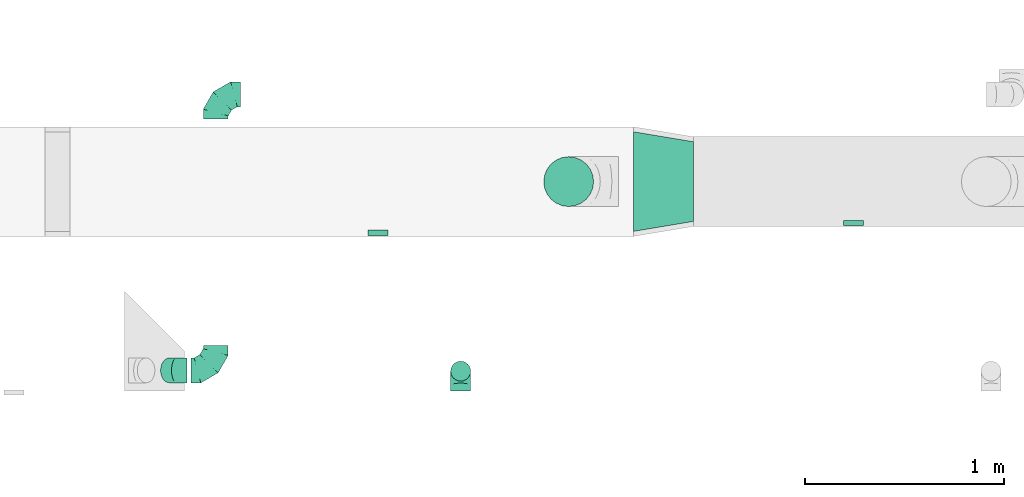
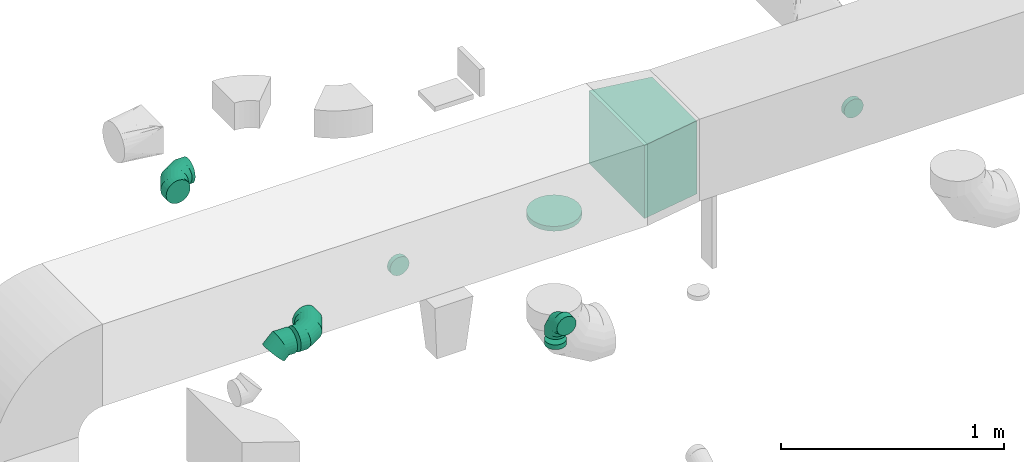
# One storey, part 61 of 97: 9 flow fittings.
"""IFC2X3 building model written with IfcOpenShell, lengths in millimetres."""

import ifcopenshell
import ifcopenshell.guid

model = None  # the IFC model being written
_history = None  # IfcOwnerHistory: only IFC2X3 demands one
_inside = {}  # id of a spatial element -> (the spatial element, [elements in it])
_under = {}  # id of a project, library or spatial element -> (it, [spatial elements below it])
_declared = {}  # id of a project -> (the project, [libraries it declares])
_typed = {}  # id of a type object -> (the type object, [elements of that type])
_made_of = {}  # id of a material, layer set ... -> (it, [elements and type objects made of it])


def new_model(schema):
    """Start an empty IFC model of exactly this schema.

    Asked for "IFC4X3", IfcOpenShell would pick the latest addendum, in which some entities
    have other attributes; the version numbers below select the first issue.
    IFC2X3 requires an IfcOwnerHistory on every rooted entity: one is made here for all.
    """
    global model, _history
    if schema == "IFC4X3":
        model = ifcopenshell.file(schema_version=(4, 3, 0, 0))
    else:
        model = ifcopenshell.file(schema=schema)
    _inside.clear()
    _under.clear()
    _declared.clear()
    _typed.clear()
    _made_of.clear()
    _history = None
    if model.schema == "IFC2X3":
        org = make("IfcOrganization", Name="unknown")
        user = make(
            "IfcPersonAndOrganization",
            ThePerson=make("IfcPerson", FamilyName="unknown"),
            TheOrganization=org,
        )
        app = make(
            "IfcApplication",
            ApplicationDeveloper=org,
            Version="unknown",
            ApplicationFullName="unknown",
            ApplicationIdentifier="unknown",
        )
        _history = make(
            "IfcOwnerHistory",
            OwningUser=user,
            OwningApplication=app,
            ChangeAction="ADDED",
            CreationDate=0,
        )
    return model


def make(cls, **values):
    """One entity of the class cls with the attributes given. An attribute that is None is left unset."""
    return model.create_entity(
        cls, **{name: value for name, value in values.items() if value is not None}
    )


def entity(cls, *values):
    """Any entity or typed value of the class cls, its attributes in the order of the schema. None: left unset."""
    e = model.create_entity(cls)
    for i, value in enumerate(values):
        if value is not None:
            e[i] = value
    return e


def rooted(cls, **values):
    """An entity with a GlobalId (a new one), such as an element, a storey or a relation."""
    return make(cls, GlobalId=ifcopenshell.guid.new(), OwnerHistory=_history, **values)


def si_unit(unit_type, name, prefix=None):
    """IfcSIUnit, for example si_unit("LENGTHUNIT", "METRE", prefix="MILLI")."""
    return make("IfcSIUnit", UnitType=unit_type, Prefix=prefix, Name=name)


def converted_unit(unit_type, name, factor, base, dimensions=None, offset=None):
    """IfcConversionBasedUnit, such as the inch: factor (a typed value) times the base unit."""
    return make(
        "IfcConversionBasedUnit"
        if offset is None
        else "IfcConversionBasedUnitWithOffset",
        ConversionOffset=offset,
        Dimensions=None
        if dimensions is None
        else entity("IfcDimensionalExponents", *dimensions),
        UnitType=unit_type,
        Name=name,
        ConversionFactor=make(
            "IfcMeasureWithUnit", ValueComponent=factor, UnitComponent=base
        ),
    )


def derived_unit(unit_type, elements):
    """IfcDerivedUnit: a product of units, each with its exponent."""
    return make(
        "IfcDerivedUnit",
        Elements=[
            make("IfcDerivedUnitElement", Unit=unit, Exponent=power)
            for unit, power in elements
        ],
        UnitType=unit_type,
    )


def assignment(units):
    """IfcUnitAssignment: the units of a project."""
    return None if units is None else make("IfcUnitAssignment", Units=units)


def point(xyz):
    """IfcCartesianPoint."""
    return None if xyz is None else make("IfcCartesianPoint", Coordinates=xyz)


def direction(xyz):
    """IfcDirection."""
    return None if xyz is None else make("IfcDirection", DirectionRatios=xyz)


def frame(location, z_axis=None, x_axis=None):
    """IfcAxis2Placement3D, a coordinate frame: its origin and axes. An axis left out is left unset."""
    return make(
        "IfcAxis2Placement3D",
        Location=point(location),
        Axis=direction(z_axis),
        RefDirection=direction(x_axis),
    )


def origin():
    """The frame at (0, 0, 0) with its axes left unset."""
    return frame((0.0, 0.0, 0.0))


def place(relative_to, where):
    """IfcLocalPlacement: puts the frame where relative to a parent placement (None: the world)."""
    return make(
        "IfcLocalPlacement", PlacementRelTo=relative_to, RelativePlacement=where
    )


def context(
    kind, dimensions, precision=None, world=None, true_north=None, identifier=None
):
    """IfcGeometricRepresentationContext, for example the 3D "Model" context."""
    return make(
        "IfcGeometricRepresentationContext",
        ContextIdentifier=identifier,
        ContextType=kind,
        CoordinateSpaceDimension=dimensions,
        Precision=precision,
        WorldCoordinateSystem=world,
        TrueNorth=true_north,
    )


def subcontext(parent, identifier, kind, view, scale=None):
    """IfcGeometricRepresentationSubContext, for example "Body" below "Model"."""
    return make(
        "IfcGeometricRepresentationSubContext",
        ContextIdentifier=identifier,
        ContextType=kind,
        ParentContext=parent,
        TargetScale=scale,
        TargetView=view,
    )


def project(units=None, contexts=None):
    """IfcProject with its units and contexts."""
    return rooted(
        "IfcProject",
        Name="project",
        RepresentationContexts=contexts,
        UnitsInContext=assignment(units),
    )


def spatial(cls, under=None, at=None, **own):
    """A site, building, storey or space (cls), placed at a placement, below another one or the project."""
    s = rooted(cls, ObjectPlacement=at, **own)
    if under is not None:
        _under.setdefault(under.id(), (under, []))[1].append(s)
    return s


def polyline(points):
    """IfcPolyline through the points."""
    return make("IfcPolyline", Points=[point(p) for p in points])


def outline(outer, holes=None, kind="AREA"):
    """IfcArbitraryClosedProfileDef: a profile drawn as a closed curve; with holes, ...WithVoids."""
    if holes is None:
        return make("IfcArbitraryClosedProfileDef", ProfileType=kind, OuterCurve=outer)
    return make(
        "IfcArbitraryProfileDefWithVoids",
        ProfileType=kind,
        OuterCurve=outer,
        InnerCurves=holes,
    )


def extrude(swept, where, along, depth):
    """IfcExtrudedAreaSolid: the profile swept, set in the frame where, extruded along a direction by depth."""
    return make(
        "IfcExtrudedAreaSolid",
        SweptArea=swept,
        Position=where,
        ExtrudedDirection=direction(along),
        Depth=depth,
    )


def faces_of(points, faces, orient=None, outer=None):
    """IfcFace entities. A face is a list of loops; a loop is a list of indices into points, from 0.

    orient and outer hold one flag for each loop. By default every Orientation is true, the
    first loop of a face is its IfcFaceOuterBound and the others are IfcFaceBound.
    """
    made = []
    for i, loops in enumerate(faces):
        bounds = []
        for j, loop in enumerate(loops):
            is_outer = j == 0 if outer is None else outer[i][j]
            bounds.append(
                make(
                    "IfcFaceOuterBound" if is_outer else "IfcFaceBound",
                    Bound=make("IfcPolyLoop", Polygon=[points[k] for k in loop]),
                    Orientation=True if orient is None else orient[i][j],
                )
            )
        made.append(make("IfcFace", Bounds=bounds))
    return made


def faceted_brep(points, faces, orient=None, outer=None, voids=None):
    """IfcFacetedBrep: a solid bounded by flat faces; with voids (closed shells), ...WithVoids."""
    shared = [point(p) for p in points]
    hull = make("IfcClosedShell", CfsFaces=faces_of(shared, faces, orient, outer))
    if voids is None:
        return make("IfcFacetedBrep", Outer=hull)
    return make(
        "IfcFacetedBrepWithVoids",
        Outer=hull,
        Voids=[
            make(cls, CfsFaces=faces_of(shared, fs, o, b)) for cls, fs, o, b in voids
        ],
    )


def shape(context_of_items, identifier, shape_type, items):
    """IfcShapeRepresentation: the items that make up one representation, for example the "Body"."""
    return make(
        "IfcShapeRepresentation",
        ContextOfItems=context_of_items,
        RepresentationIdentifier=identifier,
        RepresentationType=shape_type,
        Items=items,
    )


def source(mapping_origin, context_of_items, identifier, shape_type, items):
    """IfcRepresentationMap: a shape defined once, which mapped items show again and again."""
    return make(
        "IfcRepresentationMap",
        MappingOrigin=mapping_origin,
        MappedRepresentation=shape(context_of_items, identifier, shape_type, items),
    )


def transform(
    local_origin,
    x_axis=None,
    y_axis=None,
    z_axis=None,
    scale=None,
    scale2=None,
    scale3=None,
    uniform=True,
):
    """IfcCartesianTransformationOperator3D, or its non-uniform kind. x_axis, y_axis, z_axis: its Axis1, 2, 3."""
    if uniform:
        return make(
            "IfcCartesianTransformationOperator3D",
            Axis1=direction(x_axis),
            Axis2=direction(y_axis),
            LocalOrigin=point(local_origin),
            Scale=scale,
            Axis3=direction(z_axis),
        )
    return make(
        "IfcCartesianTransformationOperator3DnonUniform",
        Axis1=direction(x_axis),
        Axis2=direction(y_axis),
        LocalOrigin=point(local_origin),
        Scale=scale,
        Axis3=direction(z_axis),
        Scale2=scale2,
        Scale3=scale3,
    )


def mapped(mapping_source, mapping_target):
    """IfcMappedItem: shows the shape of a source again, moved by a transform."""
    return make(
        "IfcMappedItem", MappingSource=mapping_source, MappingTarget=mapping_target
    )


def material(Name=None, Category=None):
    """IfcMaterial."""
    return make("IfcMaterial", Name=Name, Category=Category)


def made_of(thing, what):
    """Note that an element or type object is made of a material, layer set ...; save() writes the relation."""
    if what is not None:
        _made_of.setdefault(what.id(), (what, []))[1].append(thing)
    return thing


def type_object(cls, material=None, **own):
    """A type object (cls), such as IfcWallType, which elements share."""
    return made_of(rooted(cls, **own), material)


def type_shapes(of_type, sources):
    """Give a type object the sources (RepresentationMaps) that its elements show as mapped items."""
    of_type.RepresentationMaps = sources


def element(
    cls,
    number,
    at=None,
    inside=None,
    cuts=None,
    type_object=None,
    material=None,
    context=None,
    identifier="Body",
    shape_type=None,
    held_by="IfcProductDefinitionShape",
    body=None,
    shapes=None,
    **own,
):
    """One element of the class cls, such as IfcWall. Its Tag is "e" and its number.

    at: its placement. inside: the storey or other place that contains it. cuts: it is an
    opening in that element (IfcRelVoidsElement). A single representation is given by context,
    identifier, shape_type and body (its items); several are given by shapes. held_by: the class
    of the entity that holds the representations. save() writes the other relations.
    """
    e = rooted(cls, Tag="e%d" % number, ObjectPlacement=at, **own)
    if body is not None:
        shapes = [shape(context, identifier, shape_type, body)]
    if shapes is not None:
        e.Representation = make(held_by, Representations=shapes)
    if inside is not None:
        _inside.setdefault(inside.id(), (inside, []))[1].append(e)
    if cuts is not None:
        rooted(
            "IfcRelVoidsElement", RelatingBuildingElement=cuts, RelatedOpeningElement=e
        )
    if type_object is not None:
        _typed.setdefault(type_object.id(), (type_object, []))[1].append(e)
    return made_of(e, material)


def aggregate(whole, parts):
    """IfcRelAggregates: a whole, such as a stair, and the parts it consists of."""
    return rooted("IfcRelAggregates", RelatingObject=whole, RelatedObjects=parts)


def save(model, path):
    """Write the relations noted so far, then the file.

    IfcRelAggregates (storeys below a building ...), IfcRelContainedInSpatialStructure (elements
    in a storey), IfcRelDefinesByType, IfcRelAssociatesMaterial and IfcRelDeclares: one each for
    every whole, place, type object, material and project.
    """
    for whole, parts in _under.values():
        aggregate(whole, parts)
    for where, things in _inside.values():
        rooted(
            "IfcRelContainedInSpatialStructure",
            RelatedElements=things,
            RelatingStructure=where,
        )
    for kind, things in _typed.values():
        rooted("IfcRelDefinesByType", RelatedObjects=things, RelatingType=kind)
    for what, things in _made_of.values():
        rooted("IfcRelAssociatesMaterial", RelatedObjects=things, RelatingMaterial=what)
    for by, libraries in _declared.values():
        rooted("IfcRelDeclares", RelatingContext=by, RelatedDefinitions=libraries)
    model.write(path)


model = new_model("IFC2X3")

# Units and contexts
model_context = context("Model", 3, precision=0.01, world=origin(), true_north=direction((6.12303176911189e-17, 1.0)))
body_context = subcontext(model_context, "Body", "Model", "MODEL_VIEW")
ifc_project = project(units=[si_unit("LENGTHUNIT", "METRE", prefix="MILLI"), si_unit("AREAUNIT", "SQUARE_METRE"), si_unit("VOLUMEUNIT", "CUBIC_METRE"), converted_unit("PLANEANGLEUNIT", "DEGREE", entity("IfcRatioMeasure", 0.0174532925199433), si_unit("PLANEANGLEUNIT", "RADIAN"), dimensions=[0, 0, 0, 0, 0, 0, 0]), si_unit("MASSUNIT", "GRAM", prefix="KILO"), derived_unit("MASSDENSITYUNIT", [(si_unit("MASSUNIT", "GRAM", prefix="KILO"), 1), (si_unit("LENGTHUNIT", "METRE"), -3)]), derived_unit("MOMENTOFINERTIAUNIT", [(si_unit("LENGTHUNIT", "METRE"), 4)]), si_unit("TIMEUNIT", "SECOND"), si_unit("FREQUENCYUNIT", "HERTZ"), si_unit("THERMODYNAMICTEMPERATUREUNIT", "DEGREE_CELSIUS"), derived_unit("THERMALTRANSMITTANCEUNIT", [(si_unit("MASSUNIT", "GRAM", prefix="KILO"), 1), (si_unit("THERMODYNAMICTEMPERATUREUNIT", "KELVIN"), -1), (si_unit("TIMEUNIT", "SECOND"), -3)]), derived_unit("VOLUMETRICFLOWRATEUNIT", [(si_unit("LENGTHUNIT", "METRE"), 3), (si_unit("TIMEUNIT", "SECOND"), -1)]), derived_unit("MASSFLOWRATEUNIT", [(si_unit("MASSUNIT", "GRAM", prefix="KILO"), 1), (si_unit("TIMEUNIT", "SECOND"), -1)]), derived_unit("ROTATIONALFREQUENCYUNIT", [(si_unit("TIMEUNIT", "SECOND"), -1)]), si_unit("ELECTRICCURRENTUNIT", "AMPERE"), si_unit("ELECTRICVOLTAGEUNIT", "VOLT"), si_unit("POWERUNIT", "WATT"), si_unit("FORCEUNIT", "NEWTON", prefix="KILO"), si_unit("ILLUMINANCEUNIT", "LUX"), si_unit("LUMINOUSFLUXUNIT", "LUMEN"), si_unit("LUMINOUSINTENSITYUNIT", "CANDELA"), derived_unit("USERDEFINED", [(si_unit("MASSUNIT", "GRAM", prefix="KILO"), -1), (si_unit("LENGTHUNIT", "METRE"), -2), (si_unit("TIMEUNIT", "SECOND"), 3), (si_unit("LUMINOUSFLUXUNIT", "LUMEN"), 1)]), derived_unit("LINEARVELOCITYUNIT", [(si_unit("LENGTHUNIT", "METRE"), 1), (si_unit("TIMEUNIT", "SECOND"), -1)]), si_unit("PRESSUREUNIT", "PASCAL"), derived_unit("USERDEFINED", [(si_unit("LENGTHUNIT", "METRE"), -2), (si_unit("MASSUNIT", "GRAM", prefix="KILO"), 1), (si_unit("TIMEUNIT", "SECOND"), -2)]), derived_unit("LINEARFORCEUNIT", [(si_unit("MASSUNIT", "GRAM", prefix="KILO"), 1), (si_unit("LENGTHUNIT", "METRE"), 1), (si_unit("TIMEUNIT", "SECOND"), -2), (si_unit("LENGTHUNIT", "METRE"), -1)]), derived_unit("PLANARFORCEUNIT", [(si_unit("MASSUNIT", "GRAM", prefix="KILO"), 1), (si_unit("LENGTHUNIT", "METRE"), 1), (si_unit("TIMEUNIT", "SECOND"), -2), (si_unit("LENGTHUNIT", "METRE"), -2)])], contexts=[model_context])

# Site, building, storey
site_placement = place(None, origin())
site = spatial("IfcSite", under=ifc_project, at=site_placement, CompositionType="ELEMENT")
building_placement = place(site_placement, origin())
building = spatial("IfcBuilding", under=site, at=building_placement, CompositionType="ELEMENT")
storey_placement = place(building_placement, frame((0.0, 0.0, -4900.0)))
storey = spatial("IfcBuildingStorey", under=building, at=storey_placement, CompositionType="ELEMENT", Elevation=-4900.0)

# Flow fittings
ifc_material = material()
duct_fitting_type_1 = type_object("IfcDuctFittingType", PredefinedType="NOTDEFINED", material=ifc_material)
shared_shape_1 = source(origin(), body_context, "Body", "SweptSolid", [
    extrude(outline(polyline([(-115.08, -221.94), (189.06, -221.94), (106.86, 271.26), (-180.84, 172.62), (-115.08, -221.94)])), frame((150.0, 0.0, -200.0), z_axis=(0.0, 0.0, 1.0), x_axis=(0.986393923832143, -0.164398987305359, 0.0)), (0.0, 0.0, 1.0), 400.0),
])
type_shapes(duct_fitting_type_1, [shared_shape_1])
flow_fitting_1_placement = place(storey_placement, frame((53521.17, 15348.96, 4050.0), z_axis=(0.0, 0.0, 1.0), x_axis=(-1.0, 0.0, 0.0)))
element("IfcFlowFitting", 1, at=flow_fitting_1_placement, inside=storey, type_object=duct_fitting_type_1, material=ifc_material, context=body_context, shape_type="MappedRepresentation", body=[
    mapped(shared_shape_1, transform((0.0, 0.0, 0.0), scale=1.0)),
])
duct_fitting_type_2 = type_object("IfcDuctFittingType", PredefinedType="NOTDEFINED", material=ifc_material)
shared_shape_2 = source(origin(), body_context, "Body", "Brep", [
    faceted_brep([(-100.0, 0.0, -50.0), (-100.0, -12.94, -48.3), (-100.0, -25.0, -43.3), (-100.0, -35.36, -35.36), (-100.0, -43.3, -25.0), (-100.0, -48.3, -12.94), (-100.0, -50.0, 0.0), (-100.0, -48.3, 12.94), (-100.0, -43.3, 25.0), (-100.0, -35.36, 35.36), (-100.0, -25.0, 43.3), (-100.0, -12.94, 48.3), (-100.0, 0.0, 50.0), (-100.0, 12.94, 48.3), (-100.0, 25.0, 43.3), (-100.0, 35.36, 35.36), (-100.0, 43.3, 25.0), (-100.0, 48.3, 12.94), (-100.0, 50.0, 0.0), (-100.0, 48.3, -12.94), (-100.0, 43.3, -25.0), (-100.0, 35.36, -35.36), (-100.0, 25.0, -43.3), (-100.0, 12.94, -48.3), (-76.67, 12.94, 48.3), (-79.9, 25.0, 43.3), (-73.21, 0.0, 50.0), (-82.68, 35.36, 35.36), (-86.15, 48.3, 12.94), (-86.6, 50.0, 0.0), (-84.81, 43.3, 25.0), (-84.81, 43.3, -25.0), (-82.68, 35.36, -35.36), (-86.15, 48.3, -12.94), (-76.67, 12.94, -48.3), (-73.21, 0.0, -50.0), (-79.9, 25.0, -43.3), (-69.74, -12.94, -48.3), (-66.51, -25.0, -43.3), (-63.73, -35.36, -35.36), (-61.6, -43.3, -25.0), (-60.26, -48.3, -12.94), (-59.81, -50.0, 0.0), (-60.26, -48.3, 12.94), (-61.6, -43.3, 25.0), (-63.73, -35.36, 35.36), (-66.51, -25.0, 43.3), (-69.74, -12.94, 48.3), (-36.27, 36.27, 48.3), (-45.1, 45.1, 43.3), (-26.79, 26.79, 50.0), (-52.68, 52.68, 35.36), (-58.49, 58.49, 25.0), (-62.15, 62.15, 12.94), (-63.4, 63.4, 0.0), (-62.15, 62.15, -12.94), (-58.49, 58.49, -25.0), (-52.68, 52.68, -35.36), (-36.27, 36.27, -48.3), (-26.79, 26.79, -50.0), (-45.1, 45.1, -43.3), (-17.32, 17.32, -48.3), (-8.49, 8.49, -43.3), (-0.91, 0.91, -35.36), (4.9, -4.9, -25.0), (8.56, -8.56, -12.94), (9.81, -9.81, 0.0), (8.56, -8.56, 12.94), (4.9, -4.9, 25.0), (-0.91, 0.91, 35.36), (-8.49, 8.49, 43.3), (-17.32, 17.32, 48.3), (-12.94, 76.67, 48.3), (-25.0, 79.9, 43.3), (0.0, 73.21, 50.0), (-35.36, 82.68, 35.36), (-43.3, 84.81, 25.0), (-48.3, 86.15, 12.94), (-50.0, 86.6, 0.0), (-48.3, 86.15, -12.94), (-43.3, 84.81, -25.0), (-35.36, 82.68, -35.36), (-12.94, 76.67, -48.3), (0.0, 73.21, -50.0), (-25.0, 79.9, -43.3), (12.94, 69.74, -48.3), (25.0, 66.51, -43.3), (35.36, 63.73, -35.36), (43.3, 61.6, -25.0), (48.3, 60.26, -12.94), (50.0, 59.81, 0.0), (48.3, 60.26, 12.94), (43.3, 61.6, 25.0), (35.36, 63.73, 35.36), (25.0, 66.51, 43.3), (12.94, 69.74, 48.3), (-12.94, 100.0, -48.3), (-25.0, 100.0, -43.3), (-35.36, 100.0, -35.36), (-43.3, 100.0, -25.0), (-48.3, 100.0, -12.94), (-50.0, 100.0, 0.0), (-48.3, 100.0, 12.94), (-43.3, 100.0, 25.0), (-35.36, 100.0, 35.36), (-25.0, 100.0, 43.3), (-12.94, 100.0, 48.3), (0.0, 100.0, 50.0), (12.94, 100.0, 48.3), (25.0, 100.0, 43.3), (35.36, 100.0, 35.36), (43.3, 100.0, 25.0), (48.3, 100.0, 12.94), (50.0, 100.0, 0.0), (48.3, 100.0, -12.94), (43.3, 100.0, -25.0), (35.36, 100.0, -35.36), (25.0, 100.0, -43.3), (12.94, 100.0, -48.3), (0.0, 100.0, -50.0)], [[[0, 1, 2, 3, 4, 5, 6, 7, 8, 9, 10, 11, 12, 13, 14, 15, 16, 17, 18, 19, 20, 21, 22, 23]], [[24, 25, 14, 13]], [[26, 24, 13, 12]], [[14, 25, 27, 15]], [[28, 29, 18, 17]], [[30, 28, 17, 16]], [[15, 27, 30, 16]], [[20, 31, 32, 21]], [[33, 31, 20, 19]], [[18, 29, 33, 19]], [[34, 35, 0, 23]], [[36, 34, 23, 22]], [[32, 36, 22, 21]], [[2, 1, 37, 38]], [[3, 2, 38, 39]], [[0, 35, 37, 1]], [[5, 4, 40, 41]], [[6, 5, 41, 42]], [[3, 39, 40, 4]], [[6, 42, 43, 7]], [[7, 43, 44, 8]], [[8, 44, 45, 9]], [[10, 46, 47, 11]], [[11, 47, 26, 12]], [[10, 9, 45, 46]], [[48, 49, 25, 24]], [[50, 48, 24, 26]], [[27, 25, 49, 51]], [[52, 53, 28, 30]], [[51, 52, 30, 27]], [[29, 28, 53, 54]], [[55, 56, 31, 33]], [[54, 55, 33, 29]], [[57, 32, 31, 56]], [[58, 59, 35, 34]], [[60, 58, 34, 36]], [[57, 60, 36, 32]], [[37, 35, 59, 61]], [[38, 37, 61, 62]], [[39, 38, 62, 63]], [[41, 40, 64, 65]], [[42, 41, 65, 66]], [[63, 64, 40, 39]], [[43, 42, 66, 67]], [[44, 43, 67, 68]], [[68, 69, 45, 44]], [[46, 45, 69, 70]], [[47, 46, 70, 71]], [[26, 47, 71, 50]], [[72, 73, 49, 48]], [[74, 72, 48, 50]], [[51, 49, 73, 75]], [[76, 77, 53, 52]], [[75, 76, 52, 51]], [[54, 53, 77, 78]], [[79, 80, 56, 55]], [[78, 79, 55, 54]], [[81, 57, 56, 80]], [[82, 83, 59, 58]], [[84, 82, 58, 60]], [[81, 84, 60, 57]], [[61, 59, 83, 85]], [[62, 61, 85, 86]], [[63, 62, 86, 87]], [[65, 64, 88, 89]], [[66, 65, 89, 90]], [[87, 88, 64, 63]], [[67, 66, 90, 91]], [[68, 67, 91, 92]], [[92, 93, 69, 68]], [[70, 69, 93, 94]], [[71, 70, 94, 95]], [[50, 71, 95, 74]], [[96, 97, 98, 99, 100, 101, 102, 103, 104, 105, 106, 107, 108, 109, 110, 111, 112, 113, 114, 115, 116, 117, 118, 119]], [[72, 74, 107, 106]], [[73, 72, 106, 105]], [[75, 73, 105, 104]], [[77, 76, 103, 102]], [[78, 77, 102, 101]], [[75, 104, 103, 76]], [[78, 101, 100, 79]], [[79, 100, 99, 80]], [[80, 99, 98, 81]], [[96, 119, 83, 82]], [[97, 96, 82, 84]], [[84, 81, 98, 97]], [[83, 119, 118, 85]], [[85, 118, 117, 86]], [[86, 117, 116, 87]], [[88, 115, 114, 89]], [[89, 114, 113, 90]], [[87, 116, 115, 88]], [[91, 90, 113, 112]], [[92, 91, 112, 111]], [[93, 92, 111, 110]], [[95, 94, 109, 108]], [[74, 95, 108, 107]], [[110, 109, 94, 93]]]),
])
type_shapes(duct_fitting_type_2, [shared_shape_2])
flow_fitting_2_placement = place(storey_placement, frame((52354.62, 14398.39, 4050.0), z_axis=(1.0, 0.0, 0.0), x_axis=(0.0, 0.0, 1.0)))
element("IfcFlowFitting", 2, at=flow_fitting_2_placement, inside=storey, type_object=duct_fitting_type_2, material=ifc_material, context=body_context, shape_type="MappedRepresentation", body=[
    mapped(shared_shape_2, transform((0.0, 0.0, 0.0), scale=1.0)),
])
duct_fitting_type_3 = type_object("IfcDuctFittingType", PredefinedType="NOTDEFINED", material=ifc_material)
shared_shape_3 = source(origin(), body_context, "Body", "Brep", [
    faceted_brep([(20.0, 0.0, -125.0), (20.0, 32.35, -120.74), (20.0, 62.5, -108.25), (20.0, 88.39, -88.39), (20.0, 108.25, -62.5), (20.0, 120.74, -32.35), (20.0, 125.0, 0.0), (20.0, 120.74, 32.35), (20.0, 108.25, 62.5), (20.0, 88.39, 88.39), (20.0, 62.5, 108.25), (20.0, 32.35, 120.74), (20.0, 0.0, 125.0), (20.0, -32.35, 120.74), (20.0, -62.5, 108.25), (20.0, -88.39, 88.39), (20.0, -108.25, 62.5), (20.0, -120.74, 32.35), (20.0, -125.0, 0.0), (20.0, -120.74, -32.35), (20.0, -108.25, -62.5), (20.0, -88.39, -88.39), (20.0, -62.5, -108.25), (20.0, -32.35, -120.74), (0.0, 0.0, 125.0), (-6.1, 0.0, 125.0), (-6.1, -32.35, 120.74), (0.0, -32.35, 120.74), (-6.1, -62.5, 108.25), (0.0, -62.5, 108.25), (0.0, -88.39, 88.39), (-6.1, -88.39, 88.39), (0.0, -108.25, 62.5), (-6.1, -108.25, 62.5), (-6.1, -120.74, 32.35), (0.0, -120.74, 32.35), (-6.1, -125.0, 0.0), (0.0, -125.0, 0.0), (-6.1, -120.74, -32.35), (0.0, -120.74, -32.35), (-6.1, -108.25, -62.5), (0.0, -108.25, -62.5), (0.0, -88.39, -88.39), (-6.1, -88.39, -88.39), (0.0, -62.5, -108.25), (-6.1, -62.5, -108.25), (-6.1, -32.35, -120.74), (0.0, -32.35, -120.74), (-6.1, 0.0, -125.0), (0.0, 0.0, -125.0), (-6.1, 32.35, -120.74), (0.0, 32.35, -120.74), (-6.1, 62.5, -108.25), (0.0, 62.5, -108.25), (0.0, 88.39, -88.39), (-6.1, 88.39, -88.39), (0.0, 108.25, -62.5), (-6.1, 108.25, -62.5), (-6.1, 120.74, -32.35), (0.0, 120.74, -32.35), (-6.1, 125.0, 0.0), (0.0, 125.0, 0.0), (-6.1, 120.74, 32.35), (0.0, 120.74, 32.35), (-6.1, 108.25, 62.5), (0.0, 108.25, 62.5), (0.0, 88.39, 88.39), (-6.1, 88.39, 88.39), (0.0, 62.5, 108.25), (-6.1, 62.5, 108.25), (-6.1, 32.35, 120.74), (0.0, 32.35, 120.74)], [[[0, 1, 2, 3, 4, 5, 6, 7, 8, 9, 10, 11, 12, 13, 14, 15, 16, 17, 18, 19, 20, 21, 22, 23]], [[13, 12, 24, 25, 26, 27]], [[14, 13, 27, 26, 28, 29]], [[30, 15, 14, 29, 28, 31]], [[17, 16, 32, 33, 34, 35]], [[18, 17, 35, 34, 36, 37]], [[32, 16, 15, 30, 31, 33]], [[19, 18, 37, 36, 38, 39]], [[20, 19, 39, 38, 40, 41]], [[42, 21, 20, 41, 40, 43]], [[23, 22, 44, 45, 46, 47]], [[0, 23, 47, 46, 48, 49]], [[44, 22, 21, 42, 43, 45]], [[1, 0, 49, 48, 50, 51]], [[2, 1, 51, 50, 52, 53]], [[54, 3, 2, 53, 52, 55]], [[5, 4, 56, 57, 58, 59]], [[6, 5, 59, 58, 60, 61]], [[56, 4, 3, 54, 55, 57]], [[7, 6, 61, 60, 62, 63]], [[8, 7, 63, 62, 64, 65]], [[66, 9, 8, 65, 64, 67]], [[11, 10, 68, 69, 70, 71]], [[12, 11, 71, 70, 25, 24]], [[68, 10, 9, 66, 67, 69]], [[46, 45, 43, 40, 38, 36, 34, 33, 31, 28, 26, 25, 70, 69, 67, 64, 62, 60, 58, 57, 55, 52, 50, 48]]]),
])
type_shapes(duct_fitting_type_3, [shared_shape_3])
flow_fitting_3_placement = place(storey_placement, frame((52896.44, 15348.96, 3850.0), z_axis=(0.0, -1.0, 0.0), x_axis=(0.0, 0.0, -1.0)))
element("IfcFlowFitting", 3, at=flow_fitting_3_placement, inside=storey, type_object=duct_fitting_type_3, material=ifc_material, context=body_context, shape_type="MappedRepresentation", body=[
    mapped(shared_shape_3, transform((0.0, 0.0, 0.0), scale=1.0)),
])
duct_fitting_type_4 = type_object("IfcDuctFittingType", PredefinedType="NOTDEFINED", material=ifc_material)
shared_shape_4 = source(origin(), body_context, "Body", "Brep", [
    faceted_brep([(-125.0, 0.0, -62.5), (-125.0, -16.18, -60.37), (-125.0, -31.25, -54.13), (-125.0, -44.19, -44.19), (-125.0, -54.13, -31.25), (-125.0, -60.37, -16.18), (-125.0, -62.5, 0.0), (-125.0, -60.37, 16.18), (-125.0, -54.13, 31.25), (-125.0, -44.19, 44.19), (-125.0, -31.25, 54.13), (-125.0, -16.18, 60.37), (-125.0, 0.0, 62.5), (-125.0, 16.18, 60.37), (-125.0, 31.25, 54.13), (-125.0, 44.19, 44.19), (-125.0, 54.13, 31.25), (-125.0, 60.37, 16.18), (-125.0, 62.5, 0.0), (-125.0, 60.37, -16.18), (-125.0, 54.13, -31.25), (-125.0, 44.19, -44.19), (-125.0, 31.25, -54.13), (-125.0, 16.18, -60.37), (-95.84, 16.18, 60.37), (-99.88, 31.25, 54.13), (-91.51, 0.0, 62.5), (-103.35, 44.19, 44.19), (-107.68, 60.37, 16.18), (-108.25, 62.5, 0.0), (-106.01, 54.13, 31.25), (-106.01, 54.13, -31.25), (-103.35, 44.19, -44.19), (-107.68, 60.37, -16.18), (-95.84, 16.18, -60.37), (-91.51, 0.0, -62.5), (-99.88, 31.25, -54.13), (-87.17, -16.18, -60.37), (-83.13, -31.25, -54.13), (-79.66, -44.19, -44.19), (-77.0, -54.13, -31.25), (-75.33, -60.37, -16.18), (-74.76, -62.5, 0.0), (-75.33, -60.37, 16.18), (-77.0, -54.13, 31.25), (-79.66, -44.19, 44.19), (-83.13, -31.25, 54.13), (-87.17, -16.18, 60.37), (-45.34, 45.34, 60.37), (-56.37, 56.37, 54.13), (-33.49, 33.49, 62.5), (-65.85, 65.85, 44.19), (-73.12, 73.12, 31.25), (-77.69, 77.69, 16.18), (-79.25, 79.25, 0.0), (-77.69, 77.69, -16.18), (-73.12, 73.12, -31.25), (-65.85, 65.85, -44.19), (-45.34, 45.34, -60.37), (-33.49, 33.49, -62.5), (-56.37, 56.37, -54.13), (-21.65, 21.65, -60.37), (-10.62, 10.62, -54.13), (-1.14, 1.14, -44.19), (6.13, -6.13, -31.25), (10.7, -10.7, -16.18), (12.26, -12.26, 0.0), (10.7, -10.7, 16.18), (6.13, -6.13, 31.25), (-1.14, 1.14, 44.19), (-10.62, 10.62, 54.13), (-21.65, 21.65, 60.37), (-16.18, 95.84, 60.37), (-31.25, 99.88, 54.13), (0.0, 91.51, 62.5), (-44.19, 103.35, 44.19), (-54.13, 106.01, 31.25), (-60.37, 107.68, 16.18), (-62.5, 108.25, 0.0), (-60.37, 107.68, -16.18), (-54.13, 106.01, -31.25), (-44.19, 103.35, -44.19), (-16.18, 95.84, -60.37), (0.0, 91.51, -62.5), (-31.25, 99.88, -54.13), (16.18, 87.17, -60.37), (31.25, 83.13, -54.13), (44.19, 79.66, -44.19), (54.13, 77.0, -31.25), (60.37, 75.33, -16.18), (62.5, 74.76, 0.0), (60.37, 75.33, 16.18), (54.13, 77.0, 31.25), (44.19, 79.66, 44.19), (31.25, 83.13, 54.13), (16.18, 87.17, 60.37), (-16.18, 125.0, -60.37), (-31.25, 125.0, -54.13), (-44.19, 125.0, -44.19), (-54.13, 125.0, -31.25), (-60.37, 125.0, -16.18), (-62.5, 125.0, 0.0), (-60.37, 125.0, 16.18), (-54.13, 125.0, 31.25), (-44.19, 125.0, 44.19), (-31.25, 125.0, 54.13), (-16.18, 125.0, 60.37), (0.0, 125.0, 62.5), (16.18, 125.0, 60.37), (31.25, 125.0, 54.13), (44.19, 125.0, 44.19), (54.13, 125.0, 31.25), (60.37, 125.0, 16.18), (62.5, 125.0, 0.0), (60.37, 125.0, -16.18), (54.13, 125.0, -31.25), (44.19, 125.0, -44.19), (31.25, 125.0, -54.13), (16.18, 125.0, -60.37), (0.0, 125.0, -62.5)], [[[0, 1, 2, 3, 4, 5, 6, 7, 8, 9, 10, 11, 12, 13, 14, 15, 16, 17, 18, 19, 20, 21, 22, 23]], [[24, 25, 14, 13]], [[26, 24, 13, 12]], [[14, 25, 27, 15]], [[28, 29, 18, 17]], [[30, 28, 17, 16]], [[15, 27, 30, 16]], [[20, 31, 32, 21]], [[33, 31, 20, 19]], [[18, 29, 33, 19]], [[34, 35, 0, 23]], [[36, 34, 23, 22]], [[21, 32, 36, 22]], [[1, 0, 35, 37]], [[2, 1, 37, 38]], [[38, 39, 3, 2]], [[5, 4, 40, 41]], [[6, 5, 41, 42]], [[39, 40, 4, 3]], [[6, 42, 43, 7]], [[7, 43, 44, 8]], [[45, 9, 8, 44]], [[9, 45, 46, 10]], [[10, 46, 47, 11]], [[26, 12, 11, 47]], [[48, 49, 25, 24]], [[50, 48, 24, 26]], [[27, 25, 49, 51]], [[52, 53, 28, 30]], [[51, 52, 30, 27]], [[29, 28, 53, 54]], [[55, 56, 31, 33]], [[54, 55, 33, 29]], [[57, 32, 31, 56]], [[58, 59, 35, 34]], [[60, 58, 34, 36]], [[57, 60, 36, 32]], [[37, 35, 59, 61]], [[38, 37, 61, 62]], [[39, 38, 62, 63]], [[41, 40, 64, 65]], [[42, 41, 65, 66]], [[63, 64, 40, 39]], [[43, 42, 66, 67]], [[44, 43, 67, 68]], [[68, 69, 45, 44]], [[46, 45, 69, 70]], [[47, 46, 70, 71]], [[26, 47, 71, 50]], [[72, 73, 49, 48]], [[74, 72, 48, 50]], [[51, 49, 73, 75]], [[76, 77, 53, 52]], [[75, 76, 52, 51]], [[54, 53, 77, 78]], [[79, 80, 56, 55]], [[78, 79, 55, 54]], [[81, 57, 56, 80]], [[82, 83, 59, 58]], [[84, 82, 58, 60]], [[81, 84, 60, 57]], [[61, 59, 83, 85]], [[62, 61, 85, 86]], [[63, 62, 86, 87]], [[65, 64, 88, 89]], [[66, 65, 89, 90]], [[87, 88, 64, 63]], [[67, 66, 90, 91]], [[68, 67, 91, 92]], [[92, 93, 69, 68]], [[70, 69, 93, 94]], [[71, 70, 94, 95]], [[50, 71, 95, 74]], [[96, 97, 98, 99, 100, 101, 102, 103, 104, 105, 106, 107, 108, 109, 110, 111, 112, 113, 114, 115, 116, 117, 118, 119]], [[72, 74, 107, 106]], [[73, 72, 106, 105]], [[75, 73, 105, 104]], [[77, 76, 103, 102]], [[78, 77, 102, 101]], [[75, 104, 103, 76]], [[78, 101, 100, 79]], [[79, 100, 99, 80]], [[80, 99, 98, 81]], [[96, 119, 83, 82]], [[97, 96, 82, 84]], [[84, 81, 98, 97]], [[83, 119, 118, 85]], [[85, 118, 117, 86]], [[116, 87, 86, 117]], [[88, 115, 114, 89]], [[89, 114, 113, 90]], [[115, 88, 87, 116]], [[91, 90, 113, 112]], [[92, 91, 112, 111]], [[111, 110, 93, 92]], [[95, 94, 109, 108]], [[74, 95, 108, 107]], [[110, 109, 94, 93]]]),
])
type_shapes(duct_fitting_type_4, [shared_shape_4])
flow_fitting_4_placement = place(storey_placement, frame((51126.36, 15786.72, 4390.0), z_axis=(0.0, 0.0, 1.0), x_axis=(-1.0, 0.0, 0.0)))
element("IfcFlowFitting", 4, at=flow_fitting_4_placement, inside=storey, type_object=duct_fitting_type_4, material=ifc_material, context=body_context, shape_type="MappedRepresentation", body=[
    mapped(shared_shape_4, transform((0.0, 0.0, 0.0), scale=1.0)),
])
flow_fitting_5_placement = place(storey_placement, frame((51126.36, 14402.31, 4390.0)))
element("IfcFlowFitting", 5, at=flow_fitting_5_placement, inside=storey, type_object=duct_fitting_type_4, material=ifc_material, context=body_context, shape_type="MappedRepresentation", body=[
    mapped(shared_shape_4, transform((0.0, 0.0, 0.0), scale=1.0)),
])
duct_fitting_type_5 = type_object("IfcDuctFittingType", PredefinedType="NOTDEFINED", material=ifc_material)
shared_shape_5 = source(origin(), body_context, "Body", "Brep", [
    faceted_brep([(-51.78, 0.0, -62.5), (-51.78, -16.18, -60.37), (-51.78, -31.25, -54.13), (-51.78, -44.19, -44.19), (-51.78, -54.13, -31.25), (-51.78, -60.37, -16.18), (-51.78, -62.5, 0.0), (-51.78, -60.37, 16.18), (-51.78, -54.13, 31.25), (-51.78, -44.19, 44.19), (-51.78, -31.25, 54.13), (-51.78, -16.18, 60.37), (-51.78, 0.0, 62.5), (-51.78, 16.18, 60.37), (-51.78, 31.25, 54.13), (-51.78, 44.19, 44.19), (-51.78, 54.13, 31.25), (-51.78, 60.37, 16.18), (-51.78, 62.5, 0.0), (-51.78, 60.37, -16.18), (-51.78, 54.13, -31.25), (-51.78, 44.19, -44.19), (-51.78, 31.25, -54.13), (-51.78, 16.18, -60.37), (-6.7, 16.18, 60.37), (-12.94, 31.25, 54.13), (0.0, 0.0, 62.5), (-18.31, 44.19, 44.19), (-22.42, 54.13, 31.25), (-25.01, 60.37, 16.18), (-25.89, 62.5, 0.0), (-25.01, 60.37, -16.18), (-22.42, 54.13, -31.25), (-18.31, 44.19, -44.19), (-6.7, 16.18, -60.37), (0.0, 0.0, -62.5), (-12.94, 31.25, -54.13), (6.7, -16.18, -60.37), (12.94, -31.25, -54.13), (18.31, -44.19, -44.19), (22.42, -54.13, -31.25), (25.01, -60.37, -16.18), (25.89, -62.5, 0.0), (25.01, -60.37, 16.18), (22.42, -54.13, 31.25), (18.31, -44.19, 44.19), (12.94, -31.25, 54.13), (6.7, -16.18, 60.37), (25.17, 48.05, 60.37), (14.51, 58.71, 54.13), (36.61, 36.61, 62.5), (5.36, 67.86, 44.19), (-1.66, 74.88, 31.25), (-6.08, 79.3, 16.18), (-7.58, 80.81, 0.0), (-6.08, 79.3, -16.18), (-1.66, 74.88, -31.25), (5.36, 67.86, -44.19), (14.51, 58.71, -54.13), (25.17, 48.05, -60.37), (36.61, 36.61, -62.5), (48.05, 25.17, -60.37), (58.71, 14.51, -54.13), (67.86, 5.36, -44.19), (74.88, -1.66, -31.25), (79.3, -6.08, -16.18), (80.81, -7.58, 0.0), (79.3, -6.08, 16.18), (74.88, -1.66, 31.25), (67.86, 5.36, 44.19), (58.71, 14.51, 54.13), (48.05, 25.17, 60.37)], [[[0, 1, 2, 3, 4, 5, 6, 7, 8, 9, 10, 11, 12, 13, 14, 15, 16, 17, 18, 19, 20, 21, 22, 23]], [[24, 25, 14, 13]], [[26, 24, 13, 12]], [[27, 15, 14, 25]], [[28, 29, 17, 16]], [[28, 16, 15, 27]], [[30, 18, 17, 29]], [[31, 32, 20, 19]], [[30, 31, 19, 18]], [[21, 20, 32, 33]], [[34, 35, 0, 23]], [[36, 34, 23, 22]], [[33, 36, 22, 21]], [[1, 0, 35, 37]], [[2, 1, 37, 38]], [[38, 39, 3, 2]], [[5, 4, 40, 41]], [[6, 5, 41, 42]], [[39, 40, 4, 3]], [[6, 42, 43, 7]], [[7, 43, 44, 8]], [[8, 44, 45, 9]], [[9, 45, 46, 10]], [[10, 46, 47, 11]], [[26, 12, 11, 47]], [[48, 49, 25, 24]], [[50, 48, 24, 26]], [[27, 25, 49, 51]], [[29, 28, 52, 53]], [[30, 29, 53, 54]], [[51, 52, 28, 27]], [[30, 54, 55, 31]], [[31, 55, 56, 32]], [[57, 33, 32, 56]], [[36, 58, 59, 34]], [[34, 59, 60, 35]], [[58, 36, 33, 57]], [[35, 60, 61, 37]], [[37, 61, 62, 38]], [[63, 39, 38, 62]], [[40, 64, 65, 41]], [[41, 65, 66, 42]], [[64, 40, 39, 63]], [[43, 42, 66, 67]], [[44, 43, 67, 68]], [[68, 69, 45, 44]], [[47, 46, 70, 71]], [[26, 47, 71, 50]], [[69, 70, 46, 45]], [[59, 58, 57, 56, 55, 54, 53, 52, 51, 49, 48, 50, 71, 70, 69, 68, 67, 66, 65, 64, 63, 62, 61, 60]]]),
])
type_shapes(duct_fitting_type_5, [shared_shape_5])
flow_fitting_6_placement = place(storey_placement, frame((50930.64, 14402.31, 4390.0), z_axis=(0.0, -1.0, 0.0), x_axis=(-1.0, 0.0, 0.0)))
element("IfcFlowFitting", 6, at=flow_fitting_6_placement, inside=storey, type_object=duct_fitting_type_5, material=ifc_material, context=body_context, shape_type="MappedRepresentation", body=[
    mapped(shared_shape_5, transform((0.0, 0.0, 0.0), scale=1.0)),
])
duct_fitting_type_6 = type_object("IfcDuctFittingType", PredefinedType="NOTDEFINED", material=ifc_material)
shared_shape_6 = source(origin(), body_context, "Body", "Brep", [
    faceted_brep([(20.0, 12.94, -48.3), (20.0, 25.0, -43.3), (20.0, 35.36, -35.36), (20.0, 43.3, -25.0), (20.0, 48.3, -12.94), (20.0, 50.0, 0.0), (20.0, 48.3, 12.94), (20.0, 43.3, 25.0), (20.0, 35.36, 35.36), (20.0, 25.0, 43.3), (20.0, 12.94, 48.3), (20.0, 0.0, 50.0), (20.0, -12.94, 48.3), (20.0, -25.0, 43.3), (20.0, -35.36, 35.36), (20.0, -43.3, 25.0), (20.0, -48.3, 12.94), (20.0, -50.0, 0.0), (20.0, -48.3, -12.94), (20.0, -43.3, -25.0), (20.0, -35.36, -35.36), (20.0, -25.0, -43.3), (20.0, -12.94, -48.3), (20.0, 0.0, -50.0), (0.0, 0.0, 50.0), (0.0, 12.94, 48.3), (-6.1, 12.94, 48.3), (-6.1, 0.0, 50.0), (0.0, 25.0, 43.3), (-6.1, 25.0, 43.3), (0.0, 35.36, 35.36), (-6.1, 35.36, 35.36), (0.0, 43.3, 25.0), (0.0, 48.3, 12.94), (-6.1, 48.3, 12.94), (-6.1, 43.3, 25.0), (0.0, 50.0, 0.0), (-6.1, 50.0, 0.0), (0.0, 48.3, -12.94), (-6.1, 48.3, -12.94), (0.0, 43.3, -25.0), (-6.1, 43.3, -25.0), (0.0, 35.36, -35.36), (-6.1, 35.36, -35.36), (0.0, 25.0, -43.3), (0.0, 12.94, -48.3), (-6.1, 12.94, -48.3), (-6.1, 25.0, -43.3), (0.0, 0.0, -50.0), (-6.1, 0.0, -50.0), (0.0, -12.94, -48.3), (-6.1, -12.94, -48.3), (0.0, -25.0, -43.3), (-6.1, -25.0, -43.3), (0.0, -35.36, -35.36), (-6.1, -35.36, -35.36), (0.0, -43.3, -25.0), (0.0, -48.3, -12.94), (-6.1, -48.3, -12.94), (-6.1, -43.3, -25.0), (0.0, -50.0, 0.0), (-6.1, -50.0, 0.0), (0.0, -48.3, 12.94), (-6.1, -48.3, 12.94), (0.0, -43.3, 25.0), (-6.1, -43.3, 25.0), (0.0, -35.36, 35.36), (-6.1, -35.36, 35.36), (0.0, -25.0, 43.3), (0.0, -12.94, 48.3), (-6.1, -12.94, 48.3), (-6.1, -25.0, 43.3)], [[[0, 1, 2, 3, 4, 5, 6, 7, 8, 9, 10, 11, 12, 13, 14, 15, 16, 17, 18, 19, 20, 21, 22, 23]], [[24, 11, 10, 25, 26, 27]], [[25, 10, 9, 28, 29, 26]], [[28, 9, 8, 30, 31, 29]], [[32, 7, 6, 33, 34, 35]], [[33, 6, 5, 36, 37, 34]], [[30, 8, 7, 32, 35, 31]], [[36, 5, 4, 38, 39, 37]], [[38, 4, 3, 40, 41, 39]], [[40, 3, 2, 42, 43, 41]], [[44, 1, 0, 45, 46, 47]], [[45, 0, 23, 48, 49, 46]], [[42, 2, 1, 44, 47, 43]], [[48, 23, 22, 50, 51, 49]], [[50, 22, 21, 52, 53, 51]], [[52, 21, 20, 54, 55, 53]], [[56, 19, 18, 57, 58, 59]], [[57, 18, 17, 60, 61, 58]], [[54, 20, 19, 56, 59, 55]], [[60, 17, 16, 62, 63, 61]], [[62, 16, 15, 64, 65, 63]], [[64, 15, 14, 66, 67, 65]], [[68, 13, 12, 69, 70, 71]], [[69, 12, 11, 24, 27, 70]], [[66, 14, 13, 68, 71, 67]], [[49, 51, 53, 55, 59, 58, 61, 63, 65, 67, 71, 70, 27, 26, 29, 31, 35, 34, 37, 39, 41, 43, 47, 46]]]),
])
type_shapes(duct_fitting_type_6, [shared_shape_6])
for number, where, z_axis, x_axis in (
    (7, (51939.09, 15098.96, 4050.0), (0.0, 0.0, -1.0), (0.0, -1.0, 0.0)),
    (8, (54324.51, 15148.96, 4050.0), (0.0, 0.0, -1.0), (0.0, -1.0, 0.0)),
    (9, (52354.62, 14398.39, 3900.0), (0.0, 1.0, 0.0), (0.0, 0.0, 1.0)),
):
    element("IfcFlowFitting", number, at=place(storey_placement, frame(where, z_axis=z_axis, x_axis=x_axis)), inside=storey, type_object=duct_fitting_type_6, material=ifc_material, context=body_context, shape_type="MappedRepresentation", body=[
        mapped(shared_shape_6, transform((0.0, 0.0, 0.0), scale=1.0)),
    ])

save(model, "model.ifc")
